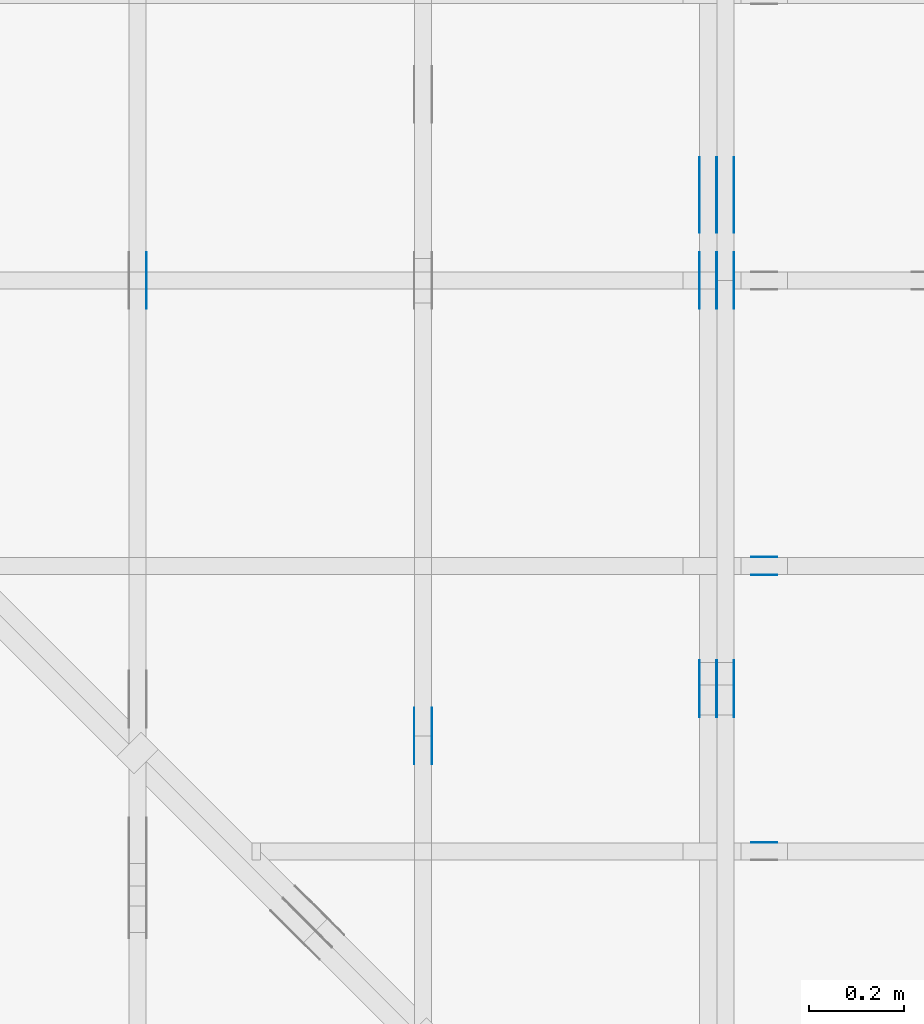
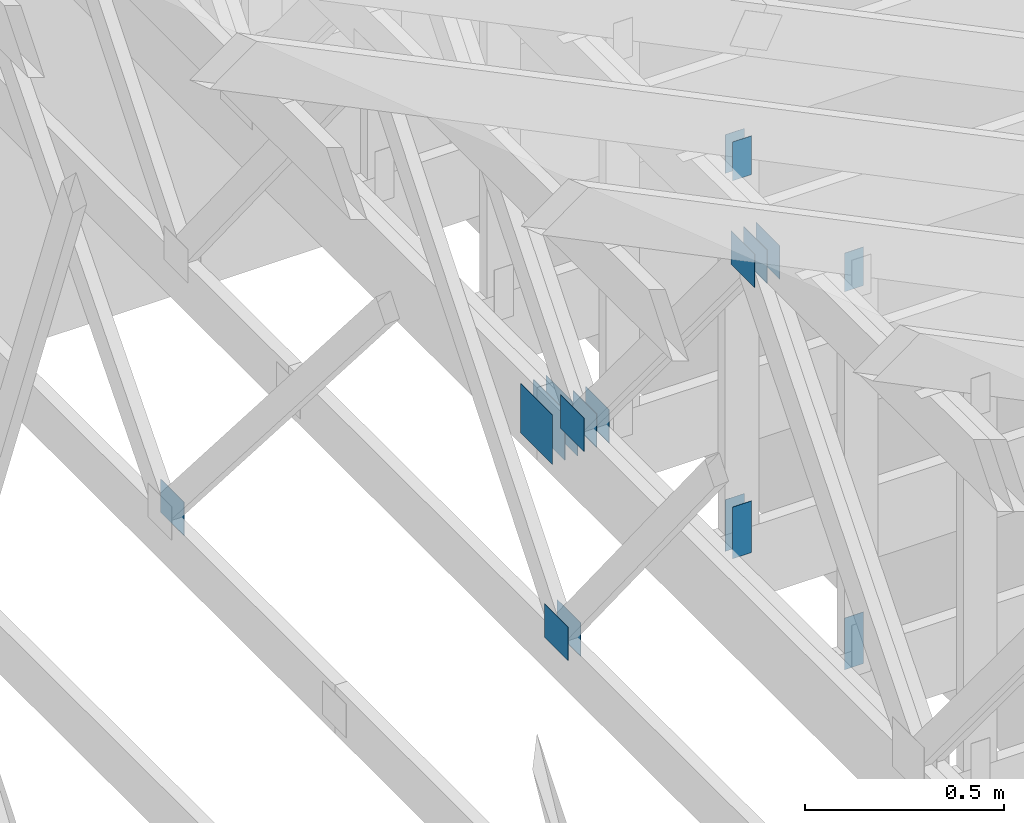
# One storey, part 120 of 159: 21 plates, 5 elements without a shape of their own.
"""IFC2X3 building model written with IfcOpenShell, lengths in millimetres."""

from ifc_helpers import new_model, si_unit, frame, origin, origin_with_axes, origin_2d, place, context, project, spatial, faceted_brep, element, aggregate, save


model = new_model("IFC2X3")

# Units and contexts
model_context = context("Model", 3, precision=1e-05, world=origin())
plan_context = context("Plan", 2, precision=1e-05, world=origin_2d())
ifc_project = project(units=[si_unit("LENGTHUNIT", "METRE", prefix="MILLI"), si_unit("AREAUNIT", "SQUARE_METRE"), si_unit("VOLUMEUNIT", "CUBIC_METRE"), si_unit("SOLIDANGLEUNIT", "STERADIAN"), si_unit("PLANEANGLEUNIT", "RADIAN"), si_unit("MASSUNIT", "GRAM"), si_unit("TIMEUNIT", "SECOND"), si_unit("THERMODYNAMICTEMPERATUREUNIT", "DEGREE_CELSIUS"), si_unit("LUMINOUSINTENSITYUNIT", "LUMEN")], contexts=[model_context, plan_context])

# Site, building, storey
site_placement = place(None, origin_with_axes())
site = spatial("IfcSite", under=ifc_project, at=site_placement, CompositionType="ELEMENT")
building_placement = place(site_placement, origin_with_axes())
building = spatial("IfcBuilding", under=site, at=building_placement, Name="Plan 1", CompositionType="ELEMENT")
storey_placement = place(building_placement, origin_with_axes())
storey = spatial("IfcBuildingStorey", under=building, at=storey_placement, Name="Etasje 1", CompositionType="ELEMENT", Elevation=0.0)

# Assembly, plates
assembly_1_placement = place(storey_placement, frame((18074.541652722903, -699.9989301294845, 4.408582873760558e-15), z_axis=(-1.0, 1.836909530733566e-16, 6.123031769111886e-17), x_axis=(-1.836909530733566e-16, -1.0, 0.0)))
assembly_1 = element("IfcElementAssembly", 1, at=assembly_1_placement, inside=storey, Name="V5 (30)", AssemblyPlace="FACTORY", PredefinedType="TRUSS")
plate_1_placement = place(assembly_1_placement, frame((-4401.388350737571, 1196.3388671875, 0.0), z_axis=(0.0, 0.0, 1.0), x_axis=(1.0, 0.0, 0.0)))
plate_1 = element("IfcPlate", 2, at=plate_1_placement, Name="GNT100S 103x119", context=model_context, shape_type="Brep", body=[
    faceted_brep([(119.00016714382127, 103.0, 1.0), (0.00016714382127247518, 103.0, 1.0), (0.00016714382127247518, 0.0, 1.0), (119.00016714382127, 0.0, 1.0), (0.00016714382127247518, 103.0, 2.0468538553242493e-20), (119.00016714382127, 103.0, 1.4572836079024844e-14), (119.00016714382127, 0.0, 1.4572836079024844e-14), (0.00016714382127247518, 0.0, 2.0468538553242493e-20), (119.0, 3.057583919686797e-05, 1.338447208185253e-30), (119.0, 3.0575839196929203e-05, 1.0), (1.1247455413666031e-32, 3.057583921878843e-05, 1.0), (0.0, 3.0575839218727197e-05, 0.0), (119.0, 103.00003057583922, 0.0), (119.0, 103.00003057583922, 1.0), (119.0, 3.0575839218727197e-05, 1.0), (119.0, 3.0575839218727197e-05, 0.0), (0.0, 103.00003057583922, 0.0), (-3.7491518045553436e-33, 103.00003057583922, 1.0), (119.0, 103.0000305758392, 1.0), (119.0, 103.0000305758392, -7.888609052210118e-31), (3.744336698070476e-21, 3.0575839218727197e-05, -2.2926692556537023e-37), (6.123406202781693e-17, 3.0575839218727197e-05, 1.0), (1.2674679506398302e-14, 103.00003057583922, 1.0), (1.2613449188707183e-14, 103.00003057583922, -7.723255010053263e-31)], [[[0, 1, 2, 3]], [[4, 5, 6, 7]], [[8, 9, 10, 11]], [[12, 13, 14, 15]], [[16, 17, 18, 19]], [[20, 21, 22, 23]]]),
])
plate_2_placement = place(assembly_1_placement, frame((-4401.388350737571, 1196.3388671875, -37.0), z_axis=(0.0, 0.0, 1.0), x_axis=(1.0, 0.0, 0.0)))
plate_2 = element("IfcPlate", 3, at=plate_2_placement, Name="GNT100S 103x119", context=model_context, shape_type="Brep", body=[
    faceted_brep([(119.00016714382127, 103.0, 1.0), (0.00016714382127247518, 103.0, 1.0), (0.00016714382127247518, 0.0, 1.0), (119.00016714382127, 0.0, 1.0), (0.00016714382127247518, 103.0, 2.0468538553242493e-20), (119.00016714382127, 103.0, 1.4572836079024844e-14), (119.00016714382127, 0.0, 1.4572836079024844e-14), (0.00016714382127247518, 0.0, 2.0468538553242493e-20), (119.0, 3.057583919686797e-05, 1.338447208185253e-30), (119.0, 3.0575839196929203e-05, 1.0), (1.1247455413666031e-32, 3.057583921878843e-05, 1.0), (0.0, 3.0575839218727197e-05, 0.0), (119.0, 103.00003057583922, 0.0), (119.0, 103.00003057583922, 1.0), (119.0, 3.0575839218727197e-05, 1.0), (119.0, 3.0575839218727197e-05, 0.0), (0.0, 103.00003057583922, 0.0), (-3.7491518045553436e-33, 103.00003057583922, 1.0), (119.0, 103.0000305758392, 1.0), (119.0, 103.0000305758392, -7.888609052210118e-31), (3.744336698070476e-21, 3.0575839218727197e-05, -2.2926692556537023e-37), (6.123406202781693e-17, 3.0575839218727197e-05, 1.0), (1.2674679506398302e-14, 103.00003057583922, 1.0), (1.2613449188707183e-14, 103.00003057583922, -7.723255010053263e-31)], [[[0, 1, 2, 3]], [[4, 5, 6, 7]], [[8, 9, 10, 11]], [[12, 13, 14, 15]], [[16, 17, 18, 19]], [[20, 21, 22, 23]]]),
])
plate_3_placement = place(assembly_1_placement, frame((-4401.388350737571, 1196.3388671875, -36.0), z_axis=(0.0, 0.0, 1.0), x_axis=(1.0, 0.0, 0.0)))
plate_3 = element("IfcPlate", 4, at=plate_3_placement, Name="GNT100S 103x119", context=model_context, shape_type="Brep", body=[
    faceted_brep([(119.00016714382127, 103.0, 1.0), (0.00016714382127247518, 103.0, 1.0), (0.00016714382127247518, 0.0, 1.0), (119.00016714382127, 0.0, 1.0), (0.00016714382127247518, 103.0, 2.0468538553242493e-20), (119.00016714382127, 103.0, 1.4572836079024844e-14), (119.00016714382127, 0.0, 1.4572836079024844e-14), (0.00016714382127247518, 0.0, 2.0468538553242493e-20), (119.0, 3.057583919686797e-05, 1.338447208185253e-30), (119.0, 3.0575839196929203e-05, 1.0), (1.1247455413666031e-32, 3.057583921878843e-05, 1.0), (0.0, 3.0575839218727197e-05, 0.0), (119.0, 103.00003057583922, 0.0), (119.0, 103.00003057583922, 1.0), (119.0, 3.0575839218727197e-05, 1.0), (119.0, 3.0575839218727197e-05, 0.0), (0.0, 103.00003057583922, 0.0), (-3.7491518045553436e-33, 103.00003057583922, 1.0), (119.0, 103.0000305758392, 1.0), (119.0, 103.0000305758392, -7.888609052210118e-31), (3.744336698070476e-21, 3.0575839218727197e-05, -2.2926692556537023e-37), (6.123406202781693e-17, 3.0575839218727197e-05, 1.0), (1.2674679506398302e-14, 103.00003057583922, 1.0), (1.2613449188707183e-14, 103.00003057583922, -7.723255010053263e-31)], [[[0, 1, 2, 3]], [[4, 5, 6, 7]], [[8, 9, 10, 11]], [[12, 13, 14, 15]], [[16, 17, 18, 19]], [[20, 21, 22, 23]]]),
])
plate_4_placement = place(assembly_1_placement, frame((-4401.388350737571, 1196.3388671875, -73.0), z_axis=(0.0, 0.0, 1.0), x_axis=(1.0, 0.0, 0.0)))
plate_4 = element("IfcPlate", 5, at=plate_4_placement, Name="GNT100S 103x119", context=model_context, shape_type="Brep", body=[
    faceted_brep([(119.00016714382127, 103.0, 1.0), (0.00016714382127247518, 103.0, 1.0), (0.00016714382127247518, 0.0, 1.0), (119.00016714382127, 0.0, 1.0), (0.00016714382127247518, 103.0, 2.0468538553242493e-20), (119.00016714382127, 103.0, 1.4572836079024844e-14), (119.00016714382127, 0.0, 1.4572836079024844e-14), (0.00016714382127247518, 0.0, 2.0468538553242493e-20), (119.0, 3.057583919686797e-05, 1.338447208185253e-30), (119.0, 3.0575839196929203e-05, 1.0), (1.1247455413666031e-32, 3.057583921878843e-05, 1.0), (0.0, 3.0575839218727197e-05, 0.0), (119.0, 103.00003057583922, 0.0), (119.0, 103.00003057583922, 1.0), (119.0, 3.0575839218727197e-05, 1.0), (119.0, 3.0575839218727197e-05, 0.0), (0.0, 103.00003057583922, 0.0), (-3.7491518045553436e-33, 103.00003057583922, 1.0), (119.0, 103.0000305758392, 1.0), (119.0, 103.0000305758392, -7.888609052210118e-31), (3.744336698070476e-21, 3.0575839218727197e-05, -2.2926692556537023e-37), (6.123406202781693e-17, 3.0575839218727197e-05, 1.0), (1.2674679506398302e-14, 103.00003057583922, 1.0), (1.2613449188707183e-14, 103.00003057583922, -7.723255010053263e-31)], [[[0, 1, 2, 3]], [[4, 5, 6, 7]], [[8, 9, 10, 11]], [[12, 13, 14, 15]], [[16, 17, 18, 19]], [[20, 21, 22, 23]]]),
])
plate_5_placement = place(assembly_1_placement, frame((-5300.5, 187.5, 0.0), z_axis=(0.0, 0.0, 1.0), x_axis=(-1.0, 1.2246063538223773e-16, 0.0)))
plate_5 = element("IfcPlate", 6, at=plate_5_placement, Name="GNT100S 152x159", context=model_context, shape_type="Brep", body=[
    faceted_brep([(159.0, 152.0, 1.0), (0.0, 152.0, 1.0), (0.0, 0.0, 1.0), (159.0, 0.0, 1.0), (0.0, 152.0, 0.0), (159.0, 152.0, 1.9471241025775798e-14), (159.0, 2.842170943040401e-14, 1.9471241025775798e-14), (0.0, 2.842170943040401e-14, 0.0), (159.0, 5.960707459302245e-13, 1.788345410772899e-30), (159.0, 5.961319762479156e-13, 1.0), (1.1247455413666031e-32, 6.253388377865793e-13, 1.0), (0.0, 6.252776074688882e-13, 0.0), (159.0, 152.00000000000063, 0.0), (159.0, 152.00000000000063, 1.0), (159.0, 6.252776074688882e-13, 1.0), (159.0, 6.252776074688882e-13, 0.0), (0.0, 152.00000000000063, 0.0), (-3.7491518045553436e-33, 152.00000000000063, 1.0), (159.0, 152.00000000000063, 1.0), (159.0, 152.00000000000063, 0.0), (7.657189310092548e-29, 6.252776074688882e-13, -4.68852134078006e-45), (6.123031769119543e-17, 6.252776074688882e-13, 1.0), (1.867524689579133e-14, 152.00000000000063, 1.0), (1.861401657810021e-14, 152.00000000000063, -1.1397421485848292e-30)], [[[0, 1, 2, 3]], [[4, 5, 6, 7]], [[8, 9, 10, 11]], [[12, 13, 14, 15]], [[16, 17, 18, 19]], [[20, 21, 22, 23]]]),
])
plate_6_placement = place(assembly_1_placement, frame((-5300.5, 187.5, -37.0), z_axis=(0.0, 0.0, 1.0), x_axis=(-1.0, 1.2246063538223773e-16, 0.0)))
plate_6 = element("IfcPlate", 7, at=plate_6_placement, Name="GNT100S 152x159", context=model_context, shape_type="Brep", body=[
    faceted_brep([(159.0, 152.0, 1.0), (0.0, 152.0, 1.0), (0.0, 0.0, 1.0), (159.0, 0.0, 1.0), (0.0, 152.0, 0.0), (159.0, 152.0, 1.9471241025775798e-14), (159.0, 2.842170943040401e-14, 1.9471241025775798e-14), (0.0, 2.842170943040401e-14, 0.0), (159.0, 5.960707459302245e-13, 1.788345410772899e-30), (159.0, 5.961319762479156e-13, 1.0), (1.1247455413666031e-32, 6.253388377865793e-13, 1.0), (0.0, 6.252776074688882e-13, 0.0), (159.0, 152.00000000000063, 0.0), (159.0, 152.00000000000063, 1.0), (159.0, 6.252776074688882e-13, 1.0), (159.0, 6.252776074688882e-13, 0.0), (0.0, 152.00000000000063, 0.0), (-3.7491518045553436e-33, 152.00000000000063, 1.0), (159.0, 152.00000000000063, 1.0), (159.0, 152.00000000000063, 0.0), (7.657189310092548e-29, 6.252776074688882e-13, -4.68852134078006e-45), (6.123031769119543e-17, 6.252776074688882e-13, 1.0), (1.867524689579133e-14, 152.00000000000063, 1.0), (1.861401657810021e-14, 152.00000000000063, -1.1397421485848292e-30)], [[[0, 1, 2, 3]], [[4, 5, 6, 7]], [[8, 9, 10, 11]], [[12, 13, 14, 15]], [[16, 17, 18, 19]], [[20, 21, 22, 23]]]),
])
plate_7_placement = place(assembly_1_placement, frame((-5300.5, 187.5, -36.0), z_axis=(0.0, 0.0, 1.0), x_axis=(-1.0, 1.2246063538223773e-16, 0.0)))
plate_7 = element("IfcPlate", 8, at=plate_7_placement, Name="GNT100S 152x159", context=model_context, shape_type="Brep", body=[
    faceted_brep([(159.0, 152.0, 1.0), (0.0, 152.0, 1.0), (0.0, 0.0, 1.0), (159.0, 0.0, 1.0), (0.0, 152.0, 0.0), (159.0, 152.0, 1.9471241025775798e-14), (159.0, 2.842170943040401e-14, 1.9471241025775798e-14), (0.0, 2.842170943040401e-14, 0.0), (159.0, 5.960707459302245e-13, 1.788345410772899e-30), (159.0, 5.961319762479156e-13, 1.0), (1.1247455413666031e-32, 6.253388377865793e-13, 1.0), (0.0, 6.252776074688882e-13, 0.0), (159.0, 152.00000000000063, 0.0), (159.0, 152.00000000000063, 1.0), (159.0, 6.252776074688882e-13, 1.0), (159.0, 6.252776074688882e-13, 0.0), (0.0, 152.00000000000063, 0.0), (-3.7491518045553436e-33, 152.00000000000063, 1.0), (159.0, 152.00000000000063, 1.0), (159.0, 152.00000000000063, 0.0), (7.657189310092548e-29, 6.252776074688882e-13, -4.68852134078006e-45), (6.123031769119543e-17, 6.252776074688882e-13, 1.0), (1.867524689579133e-14, 152.00000000000063, 1.0), (1.861401657810021e-14, 152.00000000000063, -1.1397421485848292e-30)], [[[0, 1, 2, 3]], [[4, 5, 6, 7]], [[8, 9, 10, 11]], [[12, 13, 14, 15]], [[16, 17, 18, 19]], [[20, 21, 22, 23]]]),
])
plate_8_placement = place(assembly_1_placement, frame((-5300.5, 187.5, -73.0), z_axis=(0.0, 0.0, 1.0), x_axis=(-1.0, 1.2246063538223773e-16, 0.0)))
plate_8 = element("IfcPlate", 9, at=plate_8_placement, Name="GNT100S 152x159", context=model_context, shape_type="Brep", body=[
    faceted_brep([(159.0, 152.0, 1.0), (0.0, 152.0, 1.0), (0.0, 0.0, 1.0), (159.0, 0.0, 1.0), (0.0, 152.0, 0.0), (159.0, 152.0, 1.9471241025775798e-14), (159.0, 2.842170943040401e-14, 1.9471241025775798e-14), (0.0, 2.842170943040401e-14, 0.0), (159.0, 5.960707459302245e-13, 1.788345410772899e-30), (159.0, 5.961319762479156e-13, 1.0), (1.1247455413666031e-32, 6.253388377865793e-13, 1.0), (0.0, 6.252776074688882e-13, 0.0), (159.0, 152.00000000000063, 0.0), (159.0, 152.00000000000063, 1.0), (159.0, 6.252776074688882e-13, 1.0), (159.0, 6.252776074688882e-13, 0.0), (0.0, 152.00000000000063, 0.0), (-3.7491518045553436e-33, 152.00000000000063, 1.0), (159.0, 152.00000000000063, 1.0), (159.0, 152.00000000000063, 0.0), (7.657189310092548e-29, 6.252776074688882e-13, -4.68852134078006e-45), (6.123031769119543e-17, 6.252776074688882e-13, 1.0), (1.867524689579133e-14, 152.00000000000063, 1.0), (1.861401657810021e-14, 152.00000000000063, -1.1397421485848292e-30)], [[[0, 1, 2, 3]], [[4, 5, 6, 7]], [[8, 9, 10, 11]], [[12, 13, 14, 15]], [[16, 17, 18, 19]], [[20, 21, 22, 23]]]),
])
plate_9_placement = place(assembly_1_placement, frame((-5259.49951171875, 171.4999999999994, 0.0), z_axis=(0.0, 0.0, 1.0), x_axis=(1.0, 0.0, 0.0)))
plate_9 = element("IfcPlate", 10, at=plate_9_placement, Name="GNT100S 103x119", context=model_context, shape_type="Brep", body=[
    faceted_brep([(119.0, 103.0000000000006, 1.0), (0.0, 103.0000000000006, 1.0), (0.0, 5.968558980384842e-13, 1.0), (119.0, 5.968558980384842e-13, 1.0), (0.0, 103.0000000000006, 0.0), (119.0, 103.0000000000006, 1.457281561048629e-14), (119.0, 5.968558980384842e-13, 1.457281561048629e-14), (0.0, 5.968558980384842e-13, 0.0), (119.00004665388224, -2.1859231985625525e-14, 1.338447718963718e-30), (119.00004665388224, -2.1798001667934406e-14, 1.0), (4.665388223656919e-05, 6.122174779502626e-17, 1.0), (4.665388223656919e-05, -8.569896092607535e-21, 5.247374603302376e-37), (119.00004665388224, 103.00000000000003, 0.0), (119.00004665388224, 103.00000000000003, 1.0), (119.00004665388224, 0.0, 1.0), (119.00004665388224, 0.0, 0.0), (4.665388223656919e-05, 103.00000000000003, 0.0), (4.665388223656919e-05, 103.00000000000003, 1.0), (119.00004665388224, 103.00000000000001, 1.0), (119.00004665388224, 103.00000000000001, -7.888609052210118e-31), (4.665388223656919e-05, 0.0, 0.0), (4.665388223663042e-05, -7.498303609110687e-33, 1.0), (4.6653882249243864e-05, 103.00000000000003, 1.0), (4.6653882249182634e-05, 103.00000000000003, -7.723253672473168e-31)], [[[0, 1, 2, 3]], [[4, 5, 6, 7]], [[8, 9, 10, 11]], [[12, 13, 14, 15]], [[16, 17, 18, 19]], [[20, 21, 22, 23]]]),
])
plate_10_placement = place(assembly_1_placement, frame((-5259.49951171875, 171.4999999999994, -37.0), z_axis=(0.0, 0.0, 1.0), x_axis=(1.0, 0.0, 0.0)))
plate_10 = element("IfcPlate", 11, at=plate_10_placement, Name="GNT100S 103x119", context=model_context, shape_type="Brep", body=[
    faceted_brep([(119.0, 103.0000000000006, 1.0), (0.0, 103.0000000000006, 1.0), (0.0, 5.968558980384842e-13, 1.0), (119.0, 5.968558980384842e-13, 1.0), (0.0, 103.0000000000006, 0.0), (119.0, 103.0000000000006, 1.457281561048629e-14), (119.0, 5.968558980384842e-13, 1.457281561048629e-14), (0.0, 5.968558980384842e-13, 0.0), (119.00004665388224, -2.1859231985625525e-14, 1.338447718963718e-30), (119.00004665388224, -2.1798001667934406e-14, 1.0), (4.665388223656919e-05, 6.122174779502626e-17, 1.0), (4.665388223656919e-05, -8.569896092607535e-21, 5.247374603302376e-37), (119.00004665388224, 103.00000000000003, 0.0), (119.00004665388224, 103.00000000000003, 1.0), (119.00004665388224, 0.0, 1.0), (119.00004665388224, 0.0, 0.0), (4.665388223656919e-05, 103.00000000000003, 0.0), (4.665388223656919e-05, 103.00000000000003, 1.0), (119.00004665388224, 103.00000000000001, 1.0), (119.00004665388224, 103.00000000000001, -7.888609052210118e-31), (4.665388223656919e-05, 0.0, 0.0), (4.665388223663042e-05, -7.498303609110687e-33, 1.0), (4.6653882249243864e-05, 103.00000000000003, 1.0), (4.6653882249182634e-05, 103.00000000000003, -7.723253672473168e-31)], [[[0, 1, 2, 3]], [[4, 5, 6, 7]], [[8, 9, 10, 11]], [[12, 13, 14, 15]], [[16, 17, 18, 19]], [[20, 21, 22, 23]]]),
])
plate_11_placement = place(assembly_1_placement, frame((-5259.49951171875, 171.4999999999994, -36.0), z_axis=(0.0, 0.0, 1.0), x_axis=(1.0, 0.0, 0.0)))
plate_11 = element("IfcPlate", 12, at=plate_11_placement, Name="GNT100S 103x119", context=model_context, shape_type="Brep", body=[
    faceted_brep([(119.0, 103.0000000000006, 1.0), (0.0, 103.0000000000006, 1.0), (0.0, 5.968558980384842e-13, 1.0), (119.0, 5.968558980384842e-13, 1.0), (0.0, 103.0000000000006, 0.0), (119.0, 103.0000000000006, 1.457281561048629e-14), (119.0, 5.968558980384842e-13, 1.457281561048629e-14), (0.0, 5.968558980384842e-13, 0.0), (119.00004665388224, -2.1859231985625525e-14, 1.338447718963718e-30), (119.00004665388224, -2.1798001667934406e-14, 1.0), (4.665388223656919e-05, 6.122174779502626e-17, 1.0), (4.665388223656919e-05, -8.569896092607535e-21, 5.247374603302376e-37), (119.00004665388224, 103.00000000000003, 0.0), (119.00004665388224, 103.00000000000003, 1.0), (119.00004665388224, 0.0, 1.0), (119.00004665388224, 0.0, 0.0), (4.665388223656919e-05, 103.00000000000003, 0.0), (4.665388223656919e-05, 103.00000000000003, 1.0), (119.00004665388224, 103.00000000000001, 1.0), (119.00004665388224, 103.00000000000001, -7.888609052210118e-31), (4.665388223656919e-05, 0.0, 0.0), (4.665388223663042e-05, -7.498303609110687e-33, 1.0), (4.6653882249243864e-05, 103.00000000000003, 1.0), (4.6653882249182634e-05, 103.00000000000003, -7.723253672473168e-31)], [[[0, 1, 2, 3]], [[4, 5, 6, 7]], [[8, 9, 10, 11]], [[12, 13, 14, 15]], [[16, 17, 18, 19]], [[20, 21, 22, 23]]]),
])
plate_12_placement = place(assembly_1_placement, frame((-5259.49951171875, 171.4999999999994, -73.0), z_axis=(0.0, 0.0, 1.0), x_axis=(1.0, 0.0, 0.0)))
plate_12 = element("IfcPlate", 13, at=plate_12_placement, Name="GNT100S 103x119", context=model_context, shape_type="Brep", body=[
    faceted_brep([(119.0, 103.0000000000006, 1.0), (0.0, 103.0000000000006, 1.0), (0.0, 5.968558980384842e-13, 1.0), (119.0, 5.968558980384842e-13, 1.0), (0.0, 103.0000000000006, 0.0), (119.0, 103.0000000000006, 1.457281561048629e-14), (119.0, 5.968558980384842e-13, 1.457281561048629e-14), (0.0, 5.968558980384842e-13, 0.0), (119.00004665388224, -2.1859231985625525e-14, 1.338447718963718e-30), (119.00004665388224, -2.1798001667934406e-14, 1.0), (4.665388223656919e-05, 6.122174779502626e-17, 1.0), (4.665388223656919e-05, -8.569896092607535e-21, 5.247374603302376e-37), (119.00004665388224, 103.00000000000003, 0.0), (119.00004665388224, 103.00000000000003, 1.0), (119.00004665388224, 0.0, 1.0), (119.00004665388224, 0.0, 0.0), (4.665388223656919e-05, 103.00000000000003, 0.0), (4.665388223656919e-05, 103.00000000000003, 1.0), (119.00004665388224, 103.00000000000001, 1.0), (119.00004665388224, 103.00000000000001, -7.888609052210118e-31), (4.665388223656919e-05, 0.0, 0.0), (4.665388223663042e-05, -7.498303609110687e-33, 1.0), (4.6653882249243864e-05, 103.00000000000003, 1.0), (4.6653882249182634e-05, 103.00000000000003, -7.723253672473168e-31)], [[[0, 1, 2, 3]], [[4, 5, 6, 7]], [[8, 9, 10, 11]], [[12, 13, 14, 15]], [[16, 17, 18, 19]], [[20, 21, 22, 23]]]),
])
aggregate(assembly_1, [plate_1, plate_2, plate_3, plate_4, plate_5, plate_6, plate_7, plate_8, plate_9, plate_10, plate_11, plate_12])

assembly_2_placement = place(storey_placement, frame((17475.02226140475, -699.9989301294827, 1.1021457184401395e-15), z_axis=(-1.0, 1.836909530733566e-16, 6.123031769111886e-17), x_axis=(-1.836909530733566e-16, -1.0, 0.0)))
assembly_2 = element("IfcElementAssembly", 14, at=assembly_2_placement, inside=storey, Name="V6 (31)", AssemblyPlace="FACTORY", PredefinedType="TRUSS")
plate_13_placement = place(assembly_2_placement, frame((-4183.272449103699, 422.5, 0.0), z_axis=(0.0, 0.0, 1.0), x_axis=(-1.0, 1.2246063538223773e-16, 0.0)))
plate_13 = element("IfcPlate", 15, at=plate_13_placement, Name="GNT100S 103x119", context=model_context, shape_type="Brep", body=[
    faceted_brep([(119.00001183380118, 103.0, 1.0), (1.1833801181637682e-05, 103.0, 1.0), (1.1833801181637682e-05, 0.0, 1.0), (119.00001183380118, 0.0, 1.0), (1.1833801181637682e-05, 103.0, 1.4491748116904261e-21), (119.00001183380118, 103.0, 1.45728170596611e-14), (119.00001183380118, 0.0, 1.45728170596611e-14), (1.1833801181637682e-05, 0.0, 1.4491748116904261e-21), (119.0, 4.897315463315427e-13, 1.3384471942262577e-30), (119.0, 4.897927766492338e-13, 1.0), (1.1247455413666031e-32, 5.116520000649633e-13, 1.0), (0.0, 5.115907697472721e-13, 0.0), (119.0, 103.00000000000051, 0.0), (119.0, 103.00000000000051, 1.0), (119.0, 5.115907697472721e-13, 1.0), (119.0, 5.115907697472721e-13, 0.0), (0.0, 103.00000000000051, 0.0), (-3.7491518045553436e-33, 103.00000000000051, 1.0), (119.0, 103.0000000000005, 1.0), (119.0, 103.0000000000005, -7.888609052210118e-31), (6.264973071893903e-29, 5.115907697472721e-13, -3.836062915183685e-45), (6.123031769118152e-17, 5.115907697472721e-13, 1.0), (1.2674675762061668e-14, 103.00000000000051, 1.0), (1.2613445444370549e-14, 103.00000000000051, -7.723252717384046e-31)], [[[0, 1, 2, 3]], [[4, 5, 6, 7]], [[8, 9, 10, 11]], [[12, 13, 14, 15]], [[16, 17, 18, 19]], [[20, 21, 22, 23]]]),
])
plate_14_placement = place(assembly_2_placement, frame((-4183.272449103699, 422.5, -37.0), z_axis=(0.0, 0.0, 1.0), x_axis=(-1.0, 1.2246063538223773e-16, 0.0)))
plate_14 = element("IfcPlate", 16, at=plate_14_placement, Name="GNT100S 103x119", context=model_context, shape_type="Brep", body=[
    faceted_brep([(119.00001183380118, 103.0, 1.0), (1.1833801181637682e-05, 103.0, 1.0), (1.1833801181637682e-05, 0.0, 1.0), (119.00001183380118, 0.0, 1.0), (1.1833801181637682e-05, 103.0, 1.4491748116904261e-21), (119.00001183380118, 103.0, 1.45728170596611e-14), (119.00001183380118, 0.0, 1.45728170596611e-14), (1.1833801181637682e-05, 0.0, 1.4491748116904261e-21), (119.0, 4.897315463315427e-13, 1.3384471942262577e-30), (119.0, 4.897927766492338e-13, 1.0), (1.1247455413666031e-32, 5.116520000649633e-13, 1.0), (0.0, 5.115907697472721e-13, 0.0), (119.0, 103.00000000000051, 0.0), (119.0, 103.00000000000051, 1.0), (119.0, 5.115907697472721e-13, 1.0), (119.0, 5.115907697472721e-13, 0.0), (0.0, 103.00000000000051, 0.0), (-3.7491518045553436e-33, 103.00000000000051, 1.0), (119.0, 103.0000000000005, 1.0), (119.0, 103.0000000000005, -7.888609052210118e-31), (6.264973071893903e-29, 5.115907697472721e-13, -3.836062915183685e-45), (6.123031769118152e-17, 5.115907697472721e-13, 1.0), (1.2674675762061668e-14, 103.00000000000051, 1.0), (1.2613445444370549e-14, 103.00000000000051, -7.723252717384046e-31)], [[[0, 1, 2, 3]], [[4, 5, 6, 7]], [[8, 9, 10, 11]], [[12, 13, 14, 15]], [[16, 17, 18, 19]], [[20, 21, 22, 23]]]),
])
aggregate(assembly_2, [plate_13, plate_14])

# Assembly, plate
assembly_3_placement = place(storey_placement, frame((16875.02226140475, -699.9989301294827, 1.1021457184401395e-15), z_axis=(-1.0, 1.836909530733566e-16, 6.123031769111886e-17), x_axis=(-1.836909530733566e-16, -1.0, 0.0)))
assembly_3 = element("IfcElementAssembly", 17, at=assembly_3_placement, inside=storey, Name="V7 (32)", AssemblyPlace="FACTORY", PredefinedType="TRUSS")
plate_15_placement = place(assembly_3_placement, frame((-5259.49951171875, 319.4999999999996, -37.0), z_axis=(0.0, 0.0, 1.0), x_axis=(1.0, 0.0, 0.0)))
plate_15 = element("IfcPlate", 18, at=plate_15_placement, Name="GNT100S 103x119", context=model_context, shape_type="Brep", body=[
    faceted_brep([(119.0, 103.0000000000004, 1.0), (0.0, 103.0000000000004, 1.0), (0.0, 3.979039320256561e-13, 1.0), (119.0, 3.979039320256561e-13, 1.0), (0.0, 103.0000000000004, 0.0), (119.0, 103.0000000000004, 1.457281561048629e-14), (119.0, 3.979039320256561e-13, 1.457281561048629e-14), (0.0, 3.979039320256561e-13, 0.0), (119.00004665483539, -2.185923198580061e-14, 1.3384477189744384e-30), (119.00004665483539, -2.1798001668109493e-14, 1.0), (4.6654835387016647e-05, 6.122174761994114e-17, 1.0), (4.6654835387016647e-05, -8.570071177721651e-21, 5.247481808473979e-37), (119.00004665483539, 103.0, 0.0), (119.00004665483539, 103.0, 1.0), (119.00004665483539, 0.0, 1.0), (119.00004665483539, 0.0, 0.0), (4.6654835387016647e-05, 103.0, 0.0), (4.6654835387016647e-05, 103.0, 1.0), (119.00004665483539, 102.99999999999999, 1.0), (119.00004665483539, 102.99999999999999, -7.888609052210118e-31), (4.6654835387016647e-05, 0.0, 0.0), (4.665483538707788e-05, -7.498303609110687e-33, 1.0), (4.665483539969132e-05, 103.0, 1.0), (4.665483539963009e-05, 103.0, -7.723253672473168e-31)], [[[0, 1, 2, 3]], [[4, 5, 6, 7]], [[8, 9, 10, 11]], [[12, 13, 14, 15]], [[16, 17, 18, 19]], [[20, 21, 22, 23]]]),
])
aggregate(assembly_3, [plate_15])

# Assembly, plates
assembly_4_placement = place(storey_placement, frame((21100.012663101486, 3918.0074014212582, 1.1021457184401395e-15), z_axis=(1.2246063538223773e-16, 1.0, 6.123031769111886e-17), x_axis=(-1.0, 1.2246063538223773e-16, 0.0)))
assembly_4 = element("IfcElementAssembly", 19, at=assembly_4_placement, inside=storey, Name="S14 (43)", AssemblyPlace="FACTORY", PredefinedType="TRUSS")
plate_16_placement = place(assembly_4_placement, frame((2862.490401698534, 1424.37744140625, 0.0), z_axis=(0.0, 0.0, 1.0), x_axis=(6.123031769111886e-17, -1.0, 0.0)))
plate_16 = element("IfcPlate", 20, at=plate_16_placement, Name="GNT100S 55x119", context=model_context, shape_type="Brep", body=[
    faceted_brep([(119.0, 55.00007681709121, 1.0), (0.0, 55.00007681709121, 1.0), (0.0, 7.68170912124333e-05, 1.0), (119.0, 7.68170912124333e-05, 1.0), (0.0, 55.00007681709121, 0.0), (119.0, 55.00007681709121, 1.457281561048629e-14), (119.0, 7.68170912124333e-05, 1.457281561048629e-14), (0.0, 7.68170912124333e-05, 0.0), (119.00002904618145, -2.185922875125019e-14, 1.3384475209218884e-30), (119.00002904618145, -2.179799843355907e-14, 1.0), (2.90461814529408e-05, 6.122498217036464e-17, 1.0), (2.90461814529408e-05, -5.335520754232349e-21, 3.2669563082920486e-37), (119.00002904618145, 55.0, 0.0), (119.00002904618145, 55.0, 1.0), (119.00002904618145, 0.0, 1.0), (119.00002904618145, 0.0, 0.0), (2.90461814529408e-05, 55.0, 0.0), (2.90461814529408e-05, 55.0, 1.0), (119.00002904618145, 54.99999999999999, 1.0), (119.00002904618145, 54.99999999999999, -3.944304526105059e-31), (2.90461814529408e-05, 0.0, 0.0), (2.904618145300203e-05, -7.498303609110687e-33, 1.0), (2.9046181459737365e-05, 55.0, 1.0), (2.9046181459676135e-05, 55.0, -4.124066764605687e-31)], [[[0, 1, 2, 3]], [[4, 5, 6, 7]], [[8, 9, 10, 11]], [[12, 13, 14, 15]], [[16, 17, 18, 19]], [[20, 21, 22, 23]]]),
])
plate_17_placement = place(assembly_4_placement, frame((2862.490401698534, 1424.37744140625, -37.0), z_axis=(0.0, 0.0, 1.0), x_axis=(6.123031769111886e-17, -1.0, 0.0)))
plate_17 = element("IfcPlate", 21, at=plate_17_placement, Name="GNT100S 55x119", context=model_context, shape_type="Brep", body=[
    faceted_brep([(119.0, 55.00007681709121, 1.0), (0.0, 55.00007681709121, 1.0), (0.0, 7.68170912124333e-05, 1.0), (119.0, 7.68170912124333e-05, 1.0), (0.0, 55.00007681709121, 0.0), (119.0, 55.00007681709121, 1.457281561048629e-14), (119.0, 7.68170912124333e-05, 1.457281561048629e-14), (0.0, 7.68170912124333e-05, 0.0), (119.00002904618145, -2.185922875125019e-14, 1.3384475209218884e-30), (119.00002904618145, -2.179799843355907e-14, 1.0), (2.90461814529408e-05, 6.122498217036464e-17, 1.0), (2.90461814529408e-05, -5.335520754232349e-21, 3.2669563082920486e-37), (119.00002904618145, 55.0, 0.0), (119.00002904618145, 55.0, 1.0), (119.00002904618145, 0.0, 1.0), (119.00002904618145, 0.0, 0.0), (2.90461814529408e-05, 55.0, 0.0), (2.90461814529408e-05, 55.0, 1.0), (119.00002904618145, 54.99999999999999, 1.0), (119.00002904618145, 54.99999999999999, -3.944304526105059e-31), (2.90461814529408e-05, 0.0, 0.0), (2.904618145300203e-05, -7.498303609110687e-33, 1.0), (2.9046181459737365e-05, 55.0, 1.0), (2.9046181459676135e-05, 55.0, -4.124066764605687e-31)], [[[0, 1, 2, 3]], [[4, 5, 6, 7]], [[8, 9, 10, 11]], [[12, 13, 14, 15]], [[16, 17, 18, 19]], [[20, 21, 22, 23]]]),
])
plate_18_placement = place(assembly_4_placement, frame((2917.490478515625, 143.5, 0.0), z_axis=(0.0, 0.0, 1.0), x_axis=(6.123031769111886e-17, 1.0, 0.0)))
plate_18 = element("IfcPlate", 22, at=plate_18_placement, Name="GNT100S 55x159", context=model_context, shape_type="Brep", body=[
    faceted_brep([(159.0, 55.0, 1.0), (0.0, 55.0, 1.0), (0.0, 0.0, 1.0), (159.0, 0.0, 1.0), (0.0, 55.0, 0.0), (159.0, 55.0, 1.9471241025775798e-14), (159.0, 0.0, 1.9471241025775798e-14), (0.0, 0.0, 0.0), (159.0, 7.681706480788008e-05, 1.788345571668688e-30), (159.0, 7.681706480794131e-05, 1.0), (1.1247455413666031e-32, 7.681706483714818e-05, 1.0), (0.0, 7.681706483708695e-05, 0.0), (159.0, 55.00007681706484, 0.0), (159.0, 55.00007681706484, 1.0), (159.0, 7.681706483708695e-05, 1.0), (159.0, 7.681706483708695e-05, 0.0), (-2.4308653429145085e-63, 55.00007681706484, 0.0), (-3.7491518045553436e-33, 55.00007681706484, 1.0), (159.0, 55.00007681706483, 1.0), (159.0, 55.00007681706483, -7.888609052210118e-31), (9.407066568148219e-21, 7.681706483708695e-05, -5.759976745092187e-37), (6.123972475768701e-17, 7.681706483708695e-05, 1.0), (6.796574670780762e-15, 55.00007681706484, 1.0), (6.7353443530896435e-15, 55.00007681706484, -4.124072744987623e-31)], [[[0, 1, 2, 3]], [[4, 5, 6, 7]], [[8, 9, 10, 11]], [[12, 13, 14, 15]], [[16, 17, 18, 19]], [[20, 21, 22, 23]]]),
])
plate_19_placement = place(assembly_4_placement, frame((2917.490478515625, 143.5, -37.0), z_axis=(0.0, 0.0, 1.0), x_axis=(6.123031769111886e-17, 1.0, 0.0)))
plate_19 = element("IfcPlate", 23, at=plate_19_placement, Name="GNT100S 55x159", context=model_context, shape_type="Brep", body=[
    faceted_brep([(159.0, 55.0, 1.0), (0.0, 55.0, 1.0), (0.0, 0.0, 1.0), (159.0, 0.0, 1.0), (0.0, 55.0, 0.0), (159.0, 55.0, 1.9471241025775798e-14), (159.0, 0.0, 1.9471241025775798e-14), (0.0, 0.0, 0.0), (159.0, 7.681706480788008e-05, 1.788345571668688e-30), (159.0, 7.681706480794131e-05, 1.0), (1.1247455413666031e-32, 7.681706483714818e-05, 1.0), (0.0, 7.681706483708695e-05, 0.0), (159.0, 55.00007681706484, 0.0), (159.0, 55.00007681706484, 1.0), (159.0, 7.681706483708695e-05, 1.0), (159.0, 7.681706483708695e-05, 0.0), (-2.4308653429145085e-63, 55.00007681706484, 0.0), (-3.7491518045553436e-33, 55.00007681706484, 1.0), (159.0, 55.00007681706483, 1.0), (159.0, 55.00007681706483, -7.888609052210118e-31), (9.407066568148219e-21, 7.681706483708695e-05, -5.759976745092187e-37), (6.123972475768701e-17, 7.681706483708695e-05, 1.0), (6.796574670780762e-15, 55.00007681706484, 1.0), (6.7353443530896435e-15, 55.00007681706484, -4.124072744987623e-31)], [[[0, 1, 2, 3]], [[4, 5, 6, 7]], [[8, 9, 10, 11]], [[12, 13, 14, 15]], [[16, 17, 18, 19]], [[20, 21, 22, 23]]]),
])
aggregate(assembly_4, [plate_16, plate_17, plate_18, plate_19])

assembly_5_placement = place(storey_placement, frame((21100.012663101486, 3318.0074014212582, 1.1021457184401395e-15), z_axis=(1.2246063538223773e-16, 1.0, 6.123031769111886e-17), x_axis=(-1.0, 1.2246063538223773e-16, 0.0)))
assembly_5 = element("IfcElementAssembly", 24, at=assembly_5_placement, inside=storey, Name="S15 (41)", AssemblyPlace="FACTORY", PredefinedType="TRUSS")
plate_20_placement = place(assembly_5_placement, frame((2862.490401698563, 1424.37744140625, 0.0), z_axis=(0.0, 0.0, 1.0), x_axis=(6.123031769111886e-17, -1.0, 0.0)))
plate_20 = element("IfcPlate", 25, at=plate_20_placement, Name="GNT100S 55x119", context=model_context, shape_type="Brep", body=[
    faceted_brep([(119.0, 55.00007681706211, 1.0), (0.0, 55.00007681706211, 1.0), (0.0, 7.681706210860284e-05, 1.0), (119.0, 7.681706210860284e-05, 1.0), (0.0, 55.00007681706211, 0.0), (119.0, 55.00007681706211, 1.457281561048629e-14), (119.0, 7.681706210860284e-05, 1.457281561048629e-14), (0.0, 7.681706210860284e-05, 0.0), (119.00002904577786, -2.1859228751176052e-14, 1.3384475209173491e-30), (119.00002904577786, -2.1797998433484933e-14, 1.0), (2.904577786466689e-05, 6.122498224450015e-17, 1.0), (2.904577786466689e-05, -5.335446618717665e-21, 3.2669109148808856e-37), (119.00002904577786, 55.0, 0.0), (119.00002904577786, 55.0, 1.0), (119.00002904577786, 0.0, 1.0), (119.00002904577786, 0.0, 0.0), (2.904577786466689e-05, 55.0, 0.0), (2.904577786466689e-05, 55.0, 1.0), (119.00002904577786, 54.99999999999999, 1.0), (119.00002904577786, 54.99999999999999, -3.944304526105059e-31), (2.904577786466689e-05, 0.0, 0.0), (2.904577786472812e-05, -7.498303609110687e-33, 1.0), (2.9045777871463454e-05, 55.0, 1.0), (2.9045777871402223e-05, 55.0, -4.124066764605687e-31)], [[[0, 1, 2, 3]], [[4, 5, 6, 7]], [[8, 9, 10, 11]], [[12, 13, 14, 15]], [[16, 17, 18, 19]], [[20, 21, 22, 23]]]),
])
plate_21_placement = place(assembly_5_placement, frame((2917.490478515625, 143.5, 0.0), z_axis=(0.0, 0.0, 1.0), x_axis=(6.123031769111886e-17, 1.0, 0.0)))
plate_21 = element("IfcPlate", 26, at=plate_21_placement, Name="GNT100S 55x159", context=model_context, shape_type="Brep", body=[
    faceted_brep([(159.0, 55.0, 1.0), (0.0, 55.0, 1.0), (0.0, 0.0, 1.0), (159.0, 0.0, 1.0), (0.0, 55.0, 0.0), (159.0, 55.0, 1.9471241025775798e-14), (159.0, 0.0, 1.9471241025775798e-14), (0.0, 0.0, 0.0), (159.0, 7.681706480788008e-05, 1.788345571668688e-30), (159.0, 7.681706480794131e-05, 1.0), (1.1247455413666031e-32, 7.681706483714818e-05, 1.0), (0.0, 7.681706483708695e-05, 0.0), (159.0, 55.00007681706484, 0.0), (159.0, 55.00007681706484, 1.0), (159.0, 7.681706483708695e-05, 1.0), (159.0, 7.681706483708695e-05, 0.0), (-2.4308653429145085e-63, 55.00007681706484, 0.0), (-3.7491518045553436e-33, 55.00007681706484, 1.0), (159.0, 55.00007681706483, 1.0), (159.0, 55.00007681706483, -7.888609052210118e-31), (9.407066568148219e-21, 7.681706483708695e-05, -5.759976745092187e-37), (6.123972475768701e-17, 7.681706483708695e-05, 1.0), (6.796574670780762e-15, 55.00007681706484, 1.0), (6.7353443530896435e-15, 55.00007681706484, -4.124072744987623e-31)], [[[0, 1, 2, 3]], [[4, 5, 6, 7]], [[8, 9, 10, 11]], [[12, 13, 14, 15]], [[16, 17, 18, 19]], [[20, 21, 22, 23]]]),
])
aggregate(assembly_5, [plate_20, plate_21])

save(model, "model.ifc")
